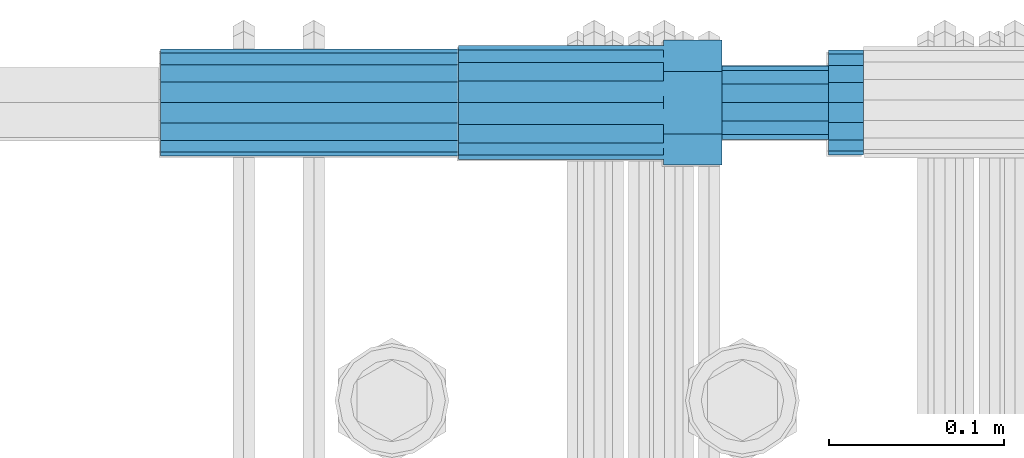
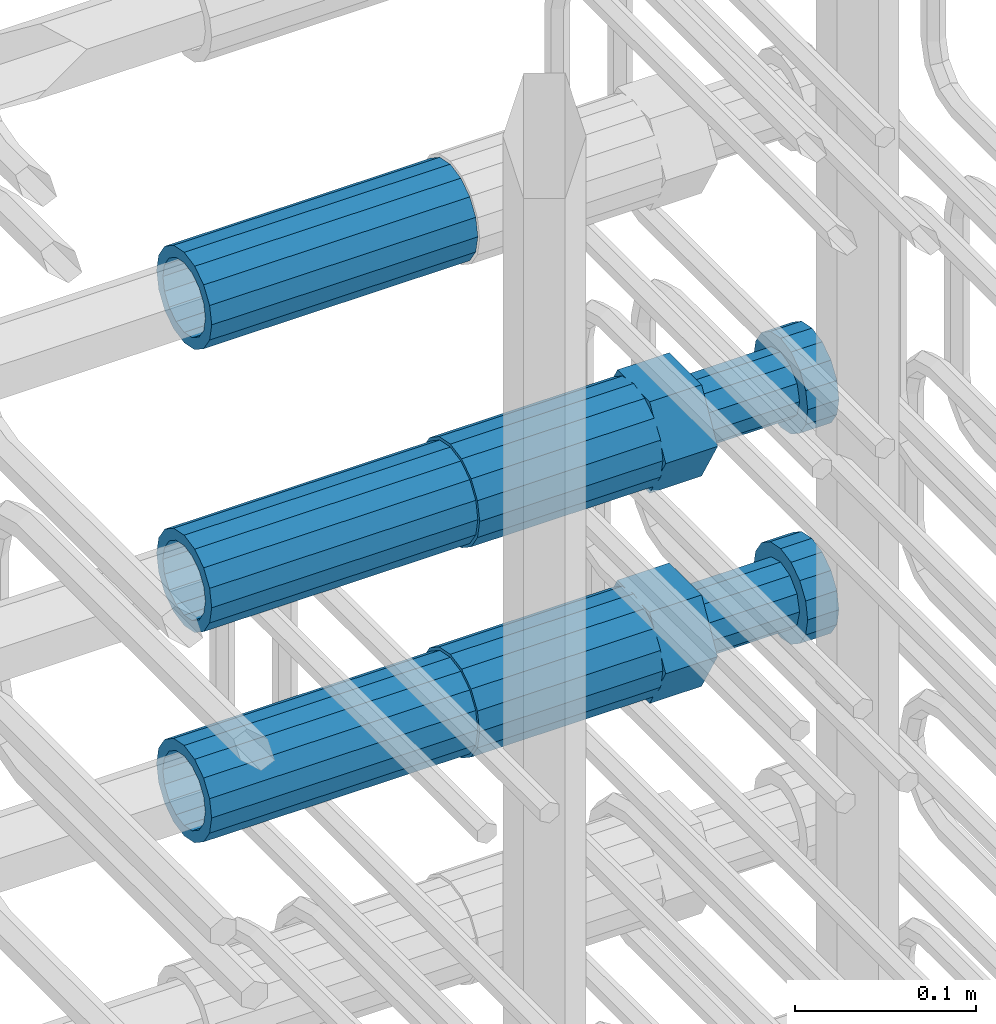
# One storey, part 53 of 177: 5 beams.
"""IFC2X3 building model written with IfcOpenShell, lengths in millimetres."""

from ifc_helpers import new_model, si_unit, frame, origin_with_axes, place, context, subcontext, project, spatial, faceted_brep, material, type_object, element, save


model = new_model("IFC2X3")

# Units and contexts
model_context_1 = context("Model", 3, precision=1e-05, world=origin_with_axes())
model_context_2 = context("Model", 3, precision=1e-05, world=origin_with_axes())
body_context = subcontext(model_context_2, "Body", "Model", "MODEL_VIEW")
ifc_project = project(units=[si_unit("LENGTHUNIT", "METRE", prefix="MILLI"), si_unit("AREAUNIT", "SQUARE_METRE"), si_unit("VOLUMEUNIT", "CUBIC_METRE"), si_unit("MASSUNIT", "GRAM", prefix="KILO"), si_unit("TIMEUNIT", "SECOND"), si_unit("PLANEANGLEUNIT", "RADIAN"), si_unit("SOLIDANGLEUNIT", "STERADIAN"), si_unit("THERMODYNAMICTEMPERATUREUNIT", "DEGREE_CELSIUS"), si_unit("LUMINOUSINTENSITYUNIT", "LUMEN")], contexts=[model_context_1])

# Site, building, storey
site_placement = place(None, origin_with_axes())
site = spatial("IfcSite", under=ifc_project, at=site_placement, CompositionType="ELEMENT")
building_placement = place(site_placement, origin_with_axes())
building = spatial("IfcBuilding", under=site, at=building_placement, Name="Undefined", CompositionType="ELEMENT")
storey_placement = place(building_placement, origin_with_axes())
storey = spatial("IfcBuildingStorey", under=building, at=storey_placement, Name="Undefined", CompositionType="ELEMENT", Elevation=0.0)

# Beams
ifc_material = material(Name="STEEL/S275")
beam_type_1 = type_object("IfcBeamType", PredefinedType="NOTDEFINED")
beam_1_placement = place(storey_placement, frame((2031449.01847313, 6206399.04588033, 20907.9868004311), z_axis=(0.0, 0.0, -1.0), x_axis=(1.0, 0.0, 0.0)))
element("IfcBeam", 1, at=beam_1_placement, inside=storey, type_object=beam_type_1, material=ifc_material, Name="AG40N", context=body_context, shape_type="Brep", body=[
    faceted_brep([(0.0, -23.5000000001164, -9.31322574615479e-10), (0.0, -21.7111690140155, 8.99306066054851), (170.0, -21.7111690140155, 8.99306066054851), (170.0, -23.5, 0.0), (0.0, -16.6170093578839, 16.6170093575493), (170.0, -16.6170093578839, 16.6170093575493), (0.0, -8.99306066057943, 21.7111690137535), (170.0, -8.99306066057943, 21.7111690137535), (0.0, 1.16415321826935e-10, 23.5), (170.0, 0.0, 23.5), (0.0, 8.99306066057943, 21.7111690137535), (170.0, 8.99306066057943, 21.7111690137535), (0.0, 16.6170093578839, 16.6170093575493), (170.0, 16.6170093578839, 16.6170093575493), (0.0, 21.7111690140155, 8.99306066054851), (170.0, 21.7111690140155, 8.99306066054851), (0.0, 23.5000000001164, -9.31322574615479e-10), (170.0, 23.5, 0.0), (0.0, 21.7111690140155, -8.99306066054851), (170.0, 21.7111690140155, -8.99306066054851), (0.0, 16.6170093578839, -16.6170093575493), (170.0, 16.6170093578839, -16.6170093575493), (0.0, 8.99306066057943, -21.7111690137535), (170.0, 8.99306066057943, -21.7111690137535), (0.0, 1.16415321826935e-10, -23.5000000009313), (170.0, 0.0, -23.5), (0.0, -8.99306066057943, -21.7111690137535), (170.0, -8.99306066057943, -21.7111690137535), (0.0, -16.6170093578839, -16.6170093575493), (170.0, -16.6170093578839, -16.6170093575493), (0.0, -21.7111690140155, -8.99306066054851), (170.0, -21.7111690140155, -8.99306066054851), (0.0, -30.5, 0.0), (0.0, -28.1783257415937, -11.6718446873128), (170.0, -28.1783257415937, -11.6718446873128), (170.0, -30.5, 0.0), (0.0, -21.5667568261888, -21.5667568258941), (170.0, -21.5667568261888, -21.5667568258941), (0.0, -11.6718446871346, -28.1783257415518), (170.0, -11.6718446871346, -28.1783257415518), (0.0, 0.0, -30.5), (170.0, 0.0, -30.5), (0.0, 11.6718446871346, -28.1783257415518), (170.0, 11.6718446871346, -28.1783257415518), (0.0, 21.5667568261888, -21.5667568258941), (170.0, 21.5667568261888, -21.5667568258941), (0.0, 28.1783257415937, -11.6718446873128), (170.0, 28.1783257415937, -11.6718446873128), (0.0, 30.5, 0.0), (170.0, 30.5, 0.0), (0.0, 28.1783257415937, 11.6718446873128), (170.0, 28.1783257415937, 11.6718446873128), (0.0, 21.5667568261888, 21.5667568258941), (170.0, 21.5667568261888, 21.5667568258941), (0.0, 11.6718446871346, 28.1783257415518), (170.0, 11.6718446871346, 28.1783257415518), (0.0, 0.0, 30.5), (170.0, 0.0, 30.5), (0.0, -11.6718446871346, 28.1783257415518), (170.0, -11.6718446871346, 28.1783257415518), (0.0, -21.5667568261888, 21.5667568258941), (170.0, -21.5667568261888, 21.5667568258941), (0.0, -28.1783257415937, 11.6718446873128), (170.0, -28.1783257415937, 11.6718446873128)], [[[0, 1, 2, 3]], [[1, 4, 5, 2]], [[4, 6, 7, 5]], [[6, 8, 9, 7]], [[8, 10, 11, 9]], [[10, 12, 13, 11]], [[12, 14, 15, 13]], [[14, 16, 17, 15]], [[16, 18, 19, 17]], [[18, 20, 21, 19]], [[20, 22, 23, 21]], [[22, 24, 25, 23]], [[24, 26, 27, 25]], [[26, 28, 29, 27]], [[28, 30, 31, 29]], [[30, 0, 3, 31]], [[32, 33, 34, 35]], [[33, 36, 37, 34]], [[36, 38, 39, 37]], [[38, 40, 41, 39]], [[40, 42, 43, 41]], [[42, 44, 45, 43]], [[44, 46, 47, 45]], [[46, 48, 49, 47]], [[48, 50, 51, 49]], [[50, 52, 53, 51]], [[52, 54, 55, 53]], [[54, 56, 57, 55]], [[56, 58, 59, 57]], [[58, 60, 61, 59]], [[60, 62, 63, 61]], [[62, 32, 35, 63]], [[37, 39, 41, 43, 45, 47, 49, 51, 53, 55, 57, 59, 61, 63, 35, 34], [5, 7, 9, 11, 13, 15, 17, 19, 21, 23, 25, 27, 29, 31, 3, 2]], [[62, 60, 58, 56, 54, 52, 50, 48, 46, 44, 42, 40, 38, 36, 33, 32], [30, 28, 26, 24, 22, 20, 18, 16, 14, 12, 10, 8, 6, 4, 1, 0]]]),
])
beam_2_placement = place(storey_placement, frame((2031449.01847313, 6206398.98588033, 21049.9868004297), z_axis=(0.0, 0.0, -1.0), x_axis=(1.0, 0.0, 0.0)))
element("IfcBeam", 2, at=beam_2_placement, inside=storey, type_object=beam_type_1, material=ifc_material, Name="AG40N", context=body_context, shape_type="Brep", body=[
    faceted_brep([(0.0, -23.5000000001164, -9.31322574615479e-10), (0.0, -21.7111690140155, 8.99306066054851), (170.0, -21.7111690140155, 8.99306066054851), (170.0, -23.5, 0.0), (0.0, -16.6170093578839, 16.6170093575493), (170.0, -16.6170093578839, 16.6170093575493), (0.0, -8.99306066057943, 21.7111690137535), (170.0, -8.99306066057943, 21.7111690137535), (0.0, 1.16415321826935e-10, 23.5), (170.0, 0.0, 23.5), (0.0, 8.99306066057943, 21.7111690137535), (170.0, 8.99306066057943, 21.7111690137535), (0.0, 16.6170093578839, 16.6170093575493), (170.0, 16.6170093578839, 16.6170093575493), (0.0, 21.7111690140155, 8.99306066054851), (170.0, 21.7111690140155, 8.99306066054851), (0.0, 23.5000000001164, -9.31322574615479e-10), (170.0, 23.5, 0.0), (0.0, 21.7111690140155, -8.99306066054851), (170.0, 21.7111690140155, -8.99306066054851), (0.0, 16.6170093578839, -16.6170093575493), (170.0, 16.6170093578839, -16.6170093575493), (0.0, 8.99306066057943, -21.7111690137535), (170.0, 8.99306066057943, -21.7111690137535), (0.0, 1.16415321826935e-10, -23.5000000009313), (170.0, 0.0, -23.5), (0.0, -8.99306066057943, -21.7111690137535), (170.0, -8.99306066057943, -21.7111690137535), (0.0, -16.6170093578839, -16.6170093575493), (170.0, -16.6170093578839, -16.6170093575493), (0.0, -21.7111690140155, -8.99306066054851), (170.0, -21.7111690140155, -8.99306066054851), (0.0, -30.5, 0.0), (0.0, -28.1783257415937, -11.6718446873128), (170.0, -28.1783257415937, -11.6718446873128), (170.0, -30.5, 0.0), (0.0, -21.5667568261888, -21.5667568258941), (170.0, -21.5667568261888, -21.5667568258941), (0.0, -11.6718446871346, -28.1783257415518), (170.0, -11.6718446871346, -28.1783257415518), (0.0, 0.0, -30.5), (170.0, 0.0, -30.5), (0.0, 11.6718446871346, -28.1783257415518), (170.0, 11.6718446871346, -28.1783257415518), (0.0, 21.5667568261888, -21.5667568258941), (170.0, 21.5667568261888, -21.5667568258941), (0.0, 28.1783257415937, -11.6718446873128), (170.0, 28.1783257415937, -11.6718446873128), (0.0, 30.5, 0.0), (170.0, 30.5, 0.0), (0.0, 28.1783257415937, 11.6718446873128), (170.0, 28.1783257415937, 11.6718446873128), (0.0, 21.5667568261888, 21.5667568258941), (170.0, 21.5667568261888, 21.5667568258941), (0.0, 11.6718446871346, 28.1783257415518), (170.0, 11.6718446871346, 28.1783257415518), (0.0, 0.0, 30.5), (170.0, 0.0, 30.5), (0.0, -11.6718446871346, 28.1783257415518), (170.0, -11.6718446871346, 28.1783257415518), (0.0, -21.5667568261888, 21.5667568258941), (170.0, -21.5667568261888, 21.5667568258941), (0.0, -28.1783257415937, 11.6718446873128), (170.0, -28.1783257415937, 11.6718446873128)], [[[0, 1, 2, 3]], [[1, 4, 5, 2]], [[4, 6, 7, 5]], [[6, 8, 9, 7]], [[8, 10, 11, 9]], [[10, 12, 13, 11]], [[12, 14, 15, 13]], [[14, 16, 17, 15]], [[16, 18, 19, 17]], [[18, 20, 21, 19]], [[20, 22, 23, 21]], [[22, 24, 25, 23]], [[24, 26, 27, 25]], [[26, 28, 29, 27]], [[28, 30, 31, 29]], [[30, 0, 3, 31]], [[32, 33, 34, 35]], [[33, 36, 37, 34]], [[36, 38, 39, 37]], [[38, 40, 41, 39]], [[40, 42, 43, 41]], [[42, 44, 45, 43]], [[44, 46, 47, 45]], [[46, 48, 49, 47]], [[48, 50, 51, 49]], [[50, 52, 53, 51]], [[52, 54, 55, 53]], [[54, 56, 57, 55]], [[56, 58, 59, 57]], [[58, 60, 61, 59]], [[60, 62, 63, 61]], [[62, 32, 35, 63]], [[37, 39, 41, 43, 45, 47, 49, 51, 53, 55, 57, 59, 61, 63, 35, 34], [5, 7, 9, 11, 13, 15, 17, 19, 21, 23, 25, 27, 29, 31, 3, 2]], [[62, 60, 58, 56, 54, 52, 50, 48, 46, 44, 42, 40, 38, 36, 33, 32], [30, 28, 26, 24, 22, 20, 18, 16, 14, 12, 10, 8, 6, 4, 1, 0]]]),
])
beam_3_placement = place(storey_placement, frame((2031449.01847313, 6206398.98588032, 21240.9868004311), z_axis=(0.0, 0.0, -1.0), x_axis=(1.0, 0.0, 0.0)))
element("IfcBeam", 3, at=beam_3_placement, inside=storey, type_object=beam_type_1, material=ifc_material, Name="AG40N", context=body_context, shape_type="Brep", body=[
    faceted_brep([(0.0, -23.5000000001164, -9.31322574615479e-10), (0.0, -21.7111690140155, 8.99306066054851), (170.0, -21.7111690140155, 8.99306066054851), (170.0, -23.5, 0.0), (0.0, -16.6170093578839, 16.6170093575493), (170.0, -16.6170093578839, 16.6170093575493), (0.0, -8.99306066057943, 21.7111690137535), (170.0, -8.99306066057943, 21.7111690137535), (0.0, 1.16415321826935e-10, 23.5), (170.0, 0.0, 23.5), (0.0, 8.99306066057943, 21.7111690137535), (170.0, 8.99306066057943, 21.7111690137535), (0.0, 16.6170093578839, 16.6170093575493), (170.0, 16.6170093578839, 16.6170093575493), (0.0, 21.7111690140155, 8.99306066054851), (170.0, 21.7111690140155, 8.99306066054851), (0.0, 23.5000000001164, -9.31322574615479e-10), (170.0, 23.5, 0.0), (0.0, 21.7111690140155, -8.99306066054851), (170.0, 21.7111690140155, -8.99306066054851), (0.0, 16.6170093578839, -16.6170093575493), (170.0, 16.6170093578839, -16.6170093575493), (0.0, 8.99306066057943, -21.7111690137535), (170.0, 8.99306066057943, -21.7111690137535), (0.0, 1.16415321826935e-10, -23.5000000009313), (170.0, 0.0, -23.5), (0.0, -8.99306066057943, -21.7111690137535), (170.0, -8.99306066057943, -21.7111690137535), (0.0, -16.6170093578839, -16.6170093575493), (170.0, -16.6170093578839, -16.6170093575493), (0.0, -21.7111690140155, -8.99306066054851), (170.0, -21.7111690140155, -8.99306066054851), (0.0, -30.5, 0.0), (0.0, -28.1783257415937, -11.6718446873128), (170.0, -28.1783257415937, -11.6718446873128), (170.0, -30.5, 0.0), (0.0, -21.5667568261888, -21.5667568258941), (170.0, -21.5667568261888, -21.5667568258941), (0.0, -11.6718446871346, -28.1783257415518), (170.0, -11.6718446871346, -28.1783257415518), (0.0, 0.0, -30.5), (170.0, 0.0, -30.5), (0.0, 11.6718446871346, -28.1783257415518), (170.0, 11.6718446871346, -28.1783257415518), (0.0, 21.5667568261888, -21.5667568258941), (170.0, 21.5667568261888, -21.5667568258941), (0.0, 28.1783257415937, -11.6718446873128), (170.0, 28.1783257415937, -11.6718446873128), (0.0, 30.5, 0.0), (170.0, 30.5, 0.0), (0.0, 28.1783257415937, 11.6718446873128), (170.0, 28.1783257415937, 11.6718446873128), (0.0, 21.5667568261888, 21.5667568258941), (170.0, 21.5667568261888, 21.5667568258941), (0.0, 11.6718446871346, 28.1783257415518), (170.0, 11.6718446871346, 28.1783257415518), (0.0, 0.0, 30.5), (170.0, 0.0, 30.5), (0.0, -11.6718446871346, 28.1783257415518), (170.0, -11.6718446871346, 28.1783257415518), (0.0, -21.5667568261888, 21.5667568258941), (170.0, -21.5667568261888, 21.5667568258941), (0.0, -28.1783257415937, 11.6718446873128), (170.0, -28.1783257415937, 11.6718446873128)], [[[0, 1, 2, 3]], [[1, 4, 5, 2]], [[4, 6, 7, 5]], [[6, 8, 9, 7]], [[8, 10, 11, 9]], [[10, 12, 13, 11]], [[12, 14, 15, 13]], [[14, 16, 17, 15]], [[16, 18, 19, 17]], [[18, 20, 21, 19]], [[20, 22, 23, 21]], [[22, 24, 25, 23]], [[24, 26, 27, 25]], [[26, 28, 29, 27]], [[28, 30, 31, 29]], [[30, 0, 3, 31]], [[32, 33, 34, 35]], [[33, 36, 37, 34]], [[36, 38, 39, 37]], [[38, 40, 41, 39]], [[40, 42, 43, 41]], [[42, 44, 45, 43]], [[44, 46, 47, 45]], [[46, 48, 49, 47]], [[48, 50, 51, 49]], [[50, 52, 53, 51]], [[52, 54, 55, 53]], [[54, 56, 57, 55]], [[56, 58, 59, 57]], [[58, 60, 61, 59]], [[60, 62, 63, 61]], [[62, 32, 35, 63]], [[37, 39, 41, 43, 45, 47, 49, 51, 53, 55, 57, 59, 61, 63, 35, 34], [5, 7, 9, 11, 13, 15, 17, 19, 21, 23, 25, 27, 29, 31, 3, 2]], [[62, 60, 58, 56, 54, 52, 50, 48, 46, 44, 42, 40, 38, 36, 33, 32], [30, 28, 26, 24, 22, 20, 18, 16, 14, 12, 10, 8, 6, 4, 1, 0]]]),
])
beam_type_2 = type_object("IfcBeamType", Name="ROD65", PredefinedType="NOTDEFINED")
beam_4_placement = place(storey_placement, frame((2031619.01847313, 6206399.04588033, 20907.9868004311), z_axis=(0.0, 0.0, -1.0), x_axis=(1.0, 0.0, 0.0)))
element("IfcBeam", 4, at=beam_4_placement, inside=storey, type_object=beam_type_2, material=ifc_material, Name="AGB40", ObjectType="ROD65", context=body_context, shape_type="Brep", body=[
    faceted_brep([(117.0, 8.17543110251427, 30.873805644922), (117.0, 17.8250000001863, 30.873805644922), (117.0, 22.0056958701462, 23.6326279877685), (117.0, 12.4372115517035, 30.0260848065373), (117.0, -17.8250000001863, 30.873805644922), (150.200000000186, -17.8250000001863, 30.873805644922), (150.200000000186, 17.8250000001863, 30.873805644922), (117.0, -8.17543110251427, 30.873805644922), (117.0, -12.4372115517035, 30.0260848065373), (117.0, -22.0056958701462, 23.6326279877685), (117.0, -35.6500000003725, 0.0), (150.200000000186, -35.6500000003725, 0.0), (117.0, -30.8443150008097, 8.32369058486074), (117.0, -32.5, 0.0), (117.0, -30.8443150008097, -8.32369058462791), (117.0, -17.8250000001863, -30.873805644922), (150.200000000186, -17.8250000001863, -30.873805644922), (117.0, -22.0056958701462, -23.6326279877685), (117.0, -12.4372115517035, -30.0260848065373), (117.0, -8.17543110251427, -30.873805644922), (117.0, 17.8250000001863, -30.873805644922), (150.200000000186, 17.8250000001863, -30.873805644922), (117.0, 8.17543110251427, -30.873805644922), (117.0, 22.0056958701462, -23.6326279877685), (117.0, 12.4372115517035, -30.0260848065373), (117.0, 35.6500000003725, 0.0), (150.200000000186, 35.6500000003725, 0.0), (117.0, 30.8443150008097, -8.32369058486074), (117.0, 30.8443150008097, 8.32369058462791), (117.0, 32.5, 0.0), (0.0, -22.9809703892097, 22.9809703885621), (0.0, -30.0260848058388, 12.4372115518636), (117.0, -30.0260848067701, 12.4372115519363), (117.0, -22.9809703882784, 22.9809703885112), (-2.3283064365387e-10, 22.9809703892097, -22.9809703885639), (-4.65661287307739e-10, 30.0260848077014, -12.4372115518672), (117.0, 30.0260848067701, -12.4372115519363), (117.0, 22.9809703882784, -22.9809703885112), (-2.3283064365387e-10, -30.0260848067701, -12.4372115518672), (-2.3283064365387e-10, -22.9809703892097, -22.9809703885621), (117.0, -22.9809703882784, -22.9809703885112), (117.0, -30.0260848067701, -12.4372115519363), (-2.3283064365387e-10, -12.4372115507722, 30.0260848066137), (-2.3283064365387e-10, 9.31322574615479e-10, 32.4999999999982), (-2.3283064365387e-10, 12.4372115526348, 30.0260848066137), (0.0, 22.9809703892097, 22.9809703885621), (-2.3283064365387e-10, 30.0260848077014, 12.4372115518636), (-2.3283064365387e-10, 32.5, 0.0), (-2.3283064365387e-10, 12.4372115526348, -30.0260848066173), (-2.3283064365387e-10, 9.31322574615479e-10, -32.5), (-2.3283064365387e-10, -12.4372115517035, -30.0260848066173), (-4.65661287307739e-10, -32.4999999990687, -1.81898940354586e-12), (117.0, 22.9809703882784, 22.9809703885112), (117.0, 30.0260848067701, 12.4372115519363), (117.0, 0.0, -32.5), (117.0, 0.0, 32.5), (150.200000000186, 10.5, -18.1865334794857), (150.200000000186, 0.0, -21.0), (150.200000000186, -10.5, -18.1865334794857), (150.200000000186, -18.18653347902, -10.5), (150.200000000186, -21.0, 0.0), (150.200000000186, -18.18653347902, 10.5), (150.200000000186, -10.5, 18.1865334794857), (150.200000000186, 0.0, 21.0), (150.200000000186, 10.5, 18.1865334794857), (150.200000000186, 18.18653347902, 10.5), (150.200000000186, 21.0, 0.0), (150.200000000186, 18.18653347902, -10.5), (210.980000000447, -18.18653347902, 10.5), (210.980000000447, -21.0, 0.0), (210.980000000447, -10.5, 18.1865334794857), (210.980000000447, 0.0, 21.0), (210.980000000447, 10.5, 18.1865334794857), (210.980000000447, 18.18653347902, 10.5), (210.980000000447, 21.0, 0.0), (210.980000000447, 18.18653347902, -10.5), (210.980000000447, 10.5, -18.1865334794857), (210.980000000447, 0.0, -21.0), (210.980000000447, -10.5, -18.1865334794857), (210.980000000447, -18.18653347902, -10.5), (211.001368442696, -27.7269937992096, -11.491116326768), (211.003082550167, -21.2238094303757, -21.223815418547), (231.002518367059, -21.2131944671273, -21.2132004550658), (231.000804259587, -27.7163788359612, -11.4805013632867), (211.001368440451, -11.4911085031927, -27.7269970395137), (231.000804257343, -11.4804935399443, -27.7163820760325), (210.996487071217, -0.0106065049767494, -30.0106107392348), (230.995922888109, 8.45827162265778e-06, -29.9999957757536), (210.989181586672, 11.46989420522, -27.7269970329944), (230.988617403564, 11.4805091684684, -27.7163820695132), (210.980564180623, 21.2025914648548, -21.2238154064398), (230.979999997515, 21.2132064281031, -21.2132004429586), (210.971946775022, 27.7057703435421, -11.4911163107026), (230.971382591913, 27.7163853067905, -11.4805013472214), (210.96464129175, 29.9893808094785, -0.0106149562634528), (230.964077108642, 29.9999957727268, 7.21774995326996e-09), (210.959759924415, 27.7057638689876, 11.4698863970116), (230.959195741307, 27.7163788322359, 11.4805013604928), (210.958045816944, 21.2025795001537, 21.2025854887906), (230.957481633835, 21.213194463402, 21.2132004522718), (210.95975992666, 11.4698785729706, 27.7057671097573), (230.959195743551, 11.480493536219, 27.7163820732385), (210.964641295894, -0.010623425245285, 29.9893808094785), (230.964077112785, -8.46199691295624e-06, 29.9999957729597), (210.971946780439, -11.4911241354421, 27.705767103238), (230.97138259733, -11.4805091721937, 27.7163820667192), (210.980564186488, -21.2238213950768, 21.2025854766835), (230.980000003379, -21.2132064318284, 21.2132004401647), (210.989181592089, -27.7270002737641, 11.4698863809463), (230.988617408981, -27.7163853105158, 11.4805013444275), (210.996487075361, -30.0106107397005, -0.0106149734929204), (230.995922892253, -29.9999957764521, -1.00117176771164e-08)], [[[0, 1, 2, 3]], [[4, 5, 6, 1, 0, 7]], [[4, 7, 8, 9]], [[10, 11, 5, 4, 9, 12]], [[10, 12, 13, 14]], [[15, 16, 11, 10, 14, 17]], [[15, 17, 18, 19]], [[20, 21, 16, 15, 19, 22]], [[23, 20, 22, 24]], [[25, 26, 21, 20, 23, 27]], [[28, 25, 27, 29]], [[30, 31, 32, 33]], [[34, 35, 36, 37]], [[38, 39, 40, 41]], [[31, 30, 42, 43, 44, 45, 46, 47, 35, 34, 48, 49, 50, 39, 38, 51]], [[46, 45, 52, 53]], [[29, 47, 46, 53, 28]], [[27, 36, 35, 47, 29]], [[23, 37, 36, 27]], [[24, 48, 34, 37, 23]], [[22, 54, 49, 48, 24]], [[19, 54, 22]], [[18, 50, 49, 54, 19]], [[17, 40, 39, 50, 18]], [[14, 41, 40, 17]], [[13, 51, 38, 41, 14]], [[12, 32, 31, 51, 13]], [[9, 33, 32, 12]], [[8, 42, 30, 33, 9]], [[7, 55, 43, 42, 8]], [[0, 55, 7]], [[3, 44, 43, 55, 0]], [[2, 52, 45, 44, 3]], [[28, 53, 52, 2]], [[1, 6, 26, 25, 28, 2]], [[5, 11, 16, 21, 26, 6], [56, 57, 58, 59, 60, 61, 62, 63, 64, 65, 66, 67]], [[68, 61, 60, 69]], [[70, 62, 61, 68]], [[71, 63, 62, 70]], [[72, 64, 63, 71]], [[73, 65, 64, 72]], [[74, 66, 65, 73]], [[75, 67, 66, 74]], [[76, 56, 67, 75]], [[77, 57, 56, 76]], [[78, 58, 57, 77]], [[79, 59, 58, 78]], [[69, 60, 59, 79]], [[80, 81, 82, 83]], [[81, 84, 85, 82]], [[84, 86, 87, 85]], [[86, 88, 89, 87]], [[88, 90, 91, 89]], [[90, 92, 93, 91]], [[92, 94, 95, 93]], [[94, 96, 97, 95]], [[96, 98, 99, 97]], [[98, 100, 101, 99]], [[100, 102, 103, 101]], [[102, 104, 105, 103]], [[104, 106, 107, 105]], [[106, 108, 109, 107]], [[108, 110, 111, 109]], [[82, 85, 87, 89, 91, 93, 95, 97, 99, 101, 103, 105, 107, 109, 111, 83]], [[110, 80, 83, 111]], [[108, 106, 104, 102, 100, 98, 96, 94, 92, 90, 88, 86, 84, 81, 80, 110], [75, 74, 73, 72, 71, 70, 68, 69, 79, 78, 77, 76]]]),
])
beam_5_placement = place(storey_placement, frame((2031619.01847313, 6206398.98588033, 21049.9868004297), z_axis=(0.0, 0.0, -1.0), x_axis=(1.0, 0.0, 0.0)))
element("IfcBeam", 5, at=beam_5_placement, inside=storey, type_object=beam_type_2, material=ifc_material, Name="AGB40", ObjectType="ROD65", context=body_context, shape_type="Brep", body=[
    faceted_brep([(117.0, 8.17543110251427, 30.873805644922), (117.0, 17.8250000001863, 30.873805644922), (117.0, 22.0056958701462, 23.6326279877685), (117.0, 12.4372115517035, 30.0260848065373), (117.0, -17.8250000001863, 30.873805644922), (150.200000000186, -17.8250000001863, 30.873805644922), (150.200000000186, 17.8250000001863, 30.873805644922), (117.0, -8.17543110251427, 30.873805644922), (117.0, -12.4372115517035, 30.0260848065373), (117.0, -22.0056958701462, 23.6326279877685), (117.0, -35.6500000003725, 0.0), (150.200000000186, -35.6500000003725, 0.0), (117.0, -30.8443150008097, 8.32369058486074), (117.0, -32.5, 0.0), (117.0, -30.8443150008097, -8.32369058462791), (117.0, -17.8250000001863, -30.873805644922), (150.200000000186, -17.8250000001863, -30.873805644922), (117.0, -22.0056958701462, -23.6326279877685), (117.0, -12.4372115517035, -30.0260848065373), (117.0, -8.17543110251427, -30.873805644922), (117.0, 17.8250000001863, -30.873805644922), (150.200000000186, 17.8250000001863, -30.873805644922), (117.0, 8.17543110251427, -30.873805644922), (117.0, 22.0056958701462, -23.6326279877685), (117.0, 12.4372115517035, -30.0260848065373), (117.0, 35.6500000003725, 0.0), (150.200000000186, 35.6500000003725, 0.0), (117.0, 30.8443150008097, -8.32369058486074), (117.0, 30.8443150008097, 8.32369058462791), (117.0, 32.5, 0.0), (0.0, -22.9809703892097, 22.9809703885621), (0.0, -30.0260848058388, 12.4372115518636), (117.0, -30.0260848067701, 12.4372115519363), (117.0, -22.9809703882784, 22.9809703885112), (-2.3283064365387e-10, 22.9809703892097, -22.9809703885639), (-4.65661287307739e-10, 30.0260848077014, -12.4372115518672), (117.0, 30.0260848067701, -12.4372115519363), (117.0, 22.9809703882784, -22.9809703885112), (-2.3283064365387e-10, -30.0260848067701, -12.4372115518672), (-2.3283064365387e-10, -22.9809703892097, -22.9809703885621), (117.0, -22.9809703882784, -22.9809703885112), (117.0, -30.0260848067701, -12.4372115519363), (-2.3283064365387e-10, -12.4372115507722, 30.0260848066137), (-2.3283064365387e-10, 9.31322574615479e-10, 32.4999999999982), (-2.3283064365387e-10, 12.4372115526348, 30.0260848066137), (0.0, 22.9809703892097, 22.9809703885621), (-2.3283064365387e-10, 30.0260848077014, 12.4372115518636), (-2.3283064365387e-10, 32.5, 0.0), (-2.3283064365387e-10, 12.4372115526348, -30.0260848066173), (-2.3283064365387e-10, 9.31322574615479e-10, -32.5), (-2.3283064365387e-10, -12.4372115517035, -30.0260848066173), (-4.65661287307739e-10, -32.4999999990687, -1.81898940354586e-12), (117.0, 22.9809703882784, 22.9809703885112), (117.0, 30.0260848067701, 12.4372115519363), (117.0, 0.0, -32.5), (117.0, 0.0, 32.5), (150.200000000186, 10.5, -18.1865334794857), (150.200000000186, 0.0, -21.0), (150.200000000186, -10.5, -18.1865334794857), (150.200000000186, -18.18653347902, -10.5), (150.200000000186, -21.0, 0.0), (150.200000000186, -18.18653347902, 10.5), (150.200000000186, -10.5, 18.1865334794857), (150.200000000186, 0.0, 21.0), (150.200000000186, 10.5, 18.1865334794857), (150.200000000186, 18.18653347902, 10.5), (150.200000000186, 21.0, 0.0), (150.200000000186, 18.18653347902, -10.5), (210.980000000447, -18.18653347902, 10.5), (210.980000000447, -21.0, 0.0), (210.980000000447, -10.5, 18.1865334794857), (210.980000000447, 0.0, 21.0), (210.980000000447, 10.5, 18.1865334794857), (210.980000000447, 18.18653347902, 10.5), (210.980000000447, 21.0, 0.0), (210.980000000447, 18.18653347902, -10.5), (210.980000000447, 10.5, -18.1865334794857), (210.980000000447, 0.0, -21.0), (210.980000000447, -10.5, -18.1865334794857), (210.980000000447, -18.18653347902, -10.5), (211.001368442696, -27.7269937992096, -11.491116326768), (211.003082550167, -21.2238094303757, -21.223815418547), (231.002518367059, -21.2131944671273, -21.2132004550658), (231.000804259587, -27.7163788359612, -11.4805013632867), (211.001368440451, -11.4911085031927, -27.7269970395137), (231.000804257343, -11.4804935399443, -27.7163820760325), (210.996487071217, -0.0106065049767494, -30.0106107392348), (230.995922888109, 8.45827162265778e-06, -29.9999957757536), (210.989181586672, 11.46989420522, -27.7269970329944), (230.988617403564, 11.4805091684684, -27.7163820695132), (210.980564180623, 21.2025914648548, -21.2238154064398), (230.979999997515, 21.2132064281031, -21.2132004429586), (210.971946775022, 27.7057703435421, -11.4911163107026), (230.971382591913, 27.7163853067905, -11.4805013472214), (210.96464129175, 29.9893808094785, -0.0106149562634528), (230.964077108642, 29.9999957727268, 7.21774995326996e-09), (210.959759924415, 27.7057638689876, 11.4698863970116), (230.959195741307, 27.7163788322359, 11.4805013604928), (210.958045816944, 21.2025795001537, 21.2025854887906), (230.957481633835, 21.213194463402, 21.2132004522718), (210.95975992666, 11.4698785729706, 27.7057671097573), (230.959195743551, 11.480493536219, 27.7163820732385), (210.964641295894, -0.010623425245285, 29.9893808094785), (230.964077112785, -8.46199691295624e-06, 29.9999957729597), (210.971946780439, -11.4911241354421, 27.705767103238), (230.97138259733, -11.4805091721937, 27.7163820667192), (210.980564186488, -21.2238213950768, 21.2025854766835), (230.980000003379, -21.2132064318284, 21.2132004401647), (210.989181592089, -27.7270002737641, 11.4698863809463), (230.988617408981, -27.7163853105158, 11.4805013444275), (210.996487075361, -30.0106107397005, -0.0106149734929204), (230.995922892253, -29.9999957764521, -1.00117176771164e-08)], [[[0, 1, 2, 3]], [[4, 5, 6, 1, 0, 7]], [[4, 7, 8, 9]], [[10, 11, 5, 4, 9, 12]], [[10, 12, 13, 14]], [[15, 16, 11, 10, 14, 17]], [[15, 17, 18, 19]], [[20, 21, 16, 15, 19, 22]], [[23, 20, 22, 24]], [[25, 26, 21, 20, 23, 27]], [[28, 25, 27, 29]], [[30, 31, 32, 33]], [[34, 35, 36, 37]], [[38, 39, 40, 41]], [[31, 30, 42, 43, 44, 45, 46, 47, 35, 34, 48, 49, 50, 39, 38, 51]], [[46, 45, 52, 53]], [[29, 47, 46, 53, 28]], [[27, 36, 35, 47, 29]], [[23, 37, 36, 27]], [[24, 48, 34, 37, 23]], [[22, 54, 49, 48, 24]], [[19, 54, 22]], [[18, 50, 49, 54, 19]], [[17, 40, 39, 50, 18]], [[14, 41, 40, 17]], [[13, 51, 38, 41, 14]], [[12, 32, 31, 51, 13]], [[9, 33, 32, 12]], [[8, 42, 30, 33, 9]], [[7, 55, 43, 42, 8]], [[0, 55, 7]], [[3, 44, 43, 55, 0]], [[2, 52, 45, 44, 3]], [[28, 53, 52, 2]], [[1, 6, 26, 25, 28, 2]], [[5, 11, 16, 21, 26, 6], [56, 57, 58, 59, 60, 61, 62, 63, 64, 65, 66, 67]], [[68, 61, 60, 69]], [[70, 62, 61, 68]], [[71, 63, 62, 70]], [[72, 64, 63, 71]], [[73, 65, 64, 72]], [[74, 66, 65, 73]], [[75, 67, 66, 74]], [[76, 56, 67, 75]], [[77, 57, 56, 76]], [[78, 58, 57, 77]], [[79, 59, 58, 78]], [[69, 60, 59, 79]], [[80, 81, 82, 83]], [[81, 84, 85, 82]], [[84, 86, 87, 85]], [[86, 88, 89, 87]], [[88, 90, 91, 89]], [[90, 92, 93, 91]], [[92, 94, 95, 93]], [[94, 96, 97, 95]], [[96, 98, 99, 97]], [[98, 100, 101, 99]], [[100, 102, 103, 101]], [[102, 104, 105, 103]], [[104, 106, 107, 105]], [[106, 108, 109, 107]], [[108, 110, 111, 109]], [[82, 85, 87, 89, 91, 93, 95, 97, 99, 101, 103, 105, 107, 109, 111, 83]], [[110, 80, 83, 111]], [[108, 106, 104, 102, 100, 98, 96, 94, 92, 90, 88, 86, 84, 81, 80, 110], [75, 74, 73, 72, 71, 70, 68, 69, 79, 78, 77, 76]]]),
])

save(model, "model.ifc")
